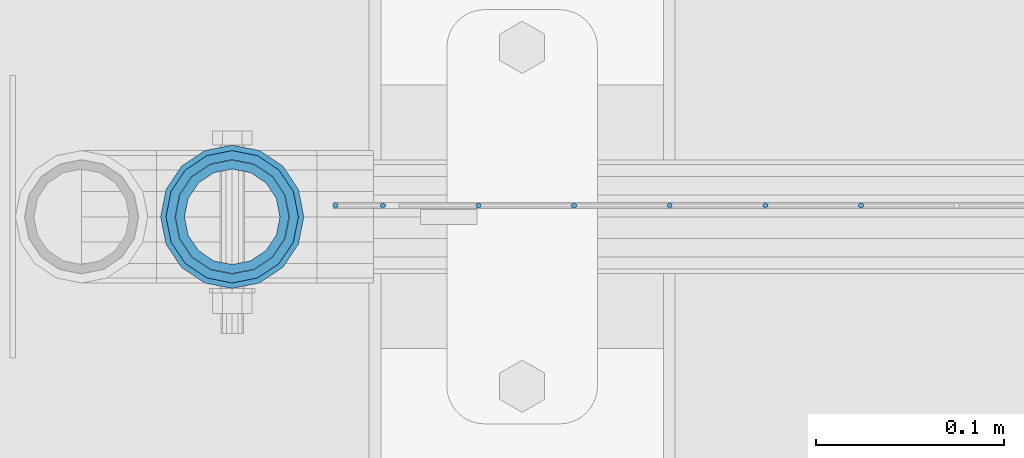
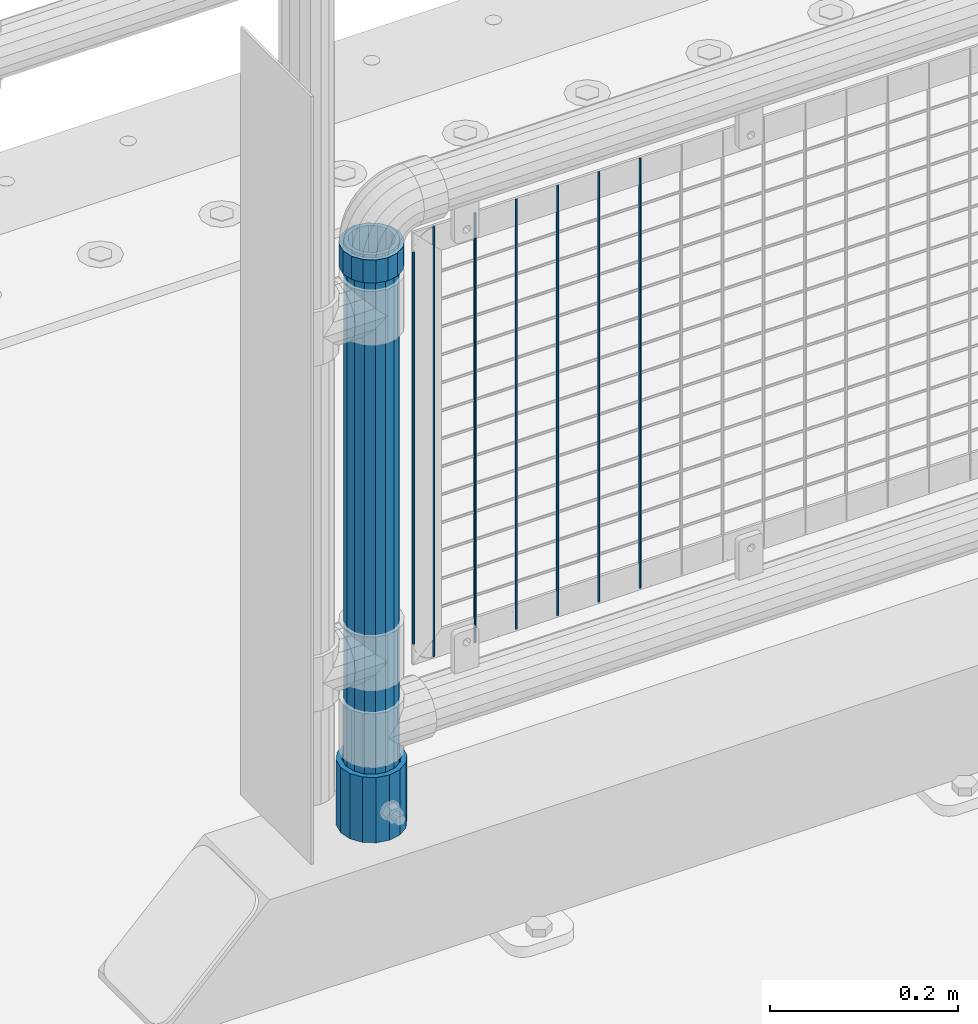
# One storey, part 61 of 242: 10 columns.
"""IFC2X3 building model written with IfcOpenShell, lengths in millimetres."""

from ifc_helpers import new_model, si_unit, frame, origin_with_axes, place, context, subcontext, project, spatial, faceted_brep, material, type_object, element, save


model = new_model("IFC2X3")

# Units and contexts
model_context = context("Model", 3, precision=1e-05, world=origin_with_axes())
body_context = subcontext(model_context, "Body", "Model", "MODEL_VIEW")
ifc_project = project(units=[si_unit("LENGTHUNIT", "METRE", prefix="MILLI"), si_unit("AREAUNIT", "SQUARE_METRE"), si_unit("VOLUMEUNIT", "CUBIC_METRE"), si_unit("MASSUNIT", "GRAM", prefix="KILO"), si_unit("TIMEUNIT", "SECOND"), si_unit("PLANEANGLEUNIT", "RADIAN"), si_unit("SOLIDANGLEUNIT", "STERADIAN"), si_unit("THERMODYNAMICTEMPERATUREUNIT", "DEGREE_CELSIUS"), si_unit("LUMINOUSINTENSITYUNIT", "LUMEN")], contexts=[model_context])

# Site, building, storey
site_placement = place(None, origin_with_axes())
site = spatial("IfcSite", under=ifc_project, at=site_placement, CompositionType="ELEMENT")
building_placement = place(site_placement, origin_with_axes())
building = spatial("IfcBuilding", under=site, at=building_placement, Name="Standard", CompositionType="ELEMENT")
storey_placement = place(building_placement, origin_with_axes())
storey = spatial("IfcBuildingStorey", under=building, at=storey_placement, Name="Undefined", CompositionType="ELEMENT", Elevation=0.0)

# Columns
ifc_material_1 = material()
column_type_1 = type_object("IfcColumnType", PredefinedType="NOTDEFINED")
column_1_placement = place(storey_placement, frame((-41829.0, -19335.5, 168.02), z_axis=(-1.0, 0.0, 0.0), x_axis=(0.0, 0.0, 1.0)))
element("IfcColumn", 1, at=column_1_placement, inside=storey, type_object=column_type_1, material=ifc_material_1, context=body_context, shape_type="Brep", body=[
    faceted_brep([(0.0, -25.3499999999985, 0.0), (0.0, -23.4203461491597, 9.70102501045403), (760.0, -23.4203461491597, 9.70102501045403), (760.0, -25.3499999999985, 0.0), (0.0, -17.9251569030785, 17.9251569030785), (760.0, -17.9251569030785, 17.9251569030785), (0.0, -9.70102501045403, 23.4203461491597), (760.0, -9.70102501045403, 23.4203461491597), (0.0, 0.0, 25.3499999999985), (760.0, 0.0, 25.3499999999985), (0.0, 9.70102501045403, 23.4203461491597), (760.0, 9.70102501045403, 23.4203461491597), (0.0, 17.9251569030785, 17.9251569030785), (760.0, 17.9251569030785, 17.9251569030785), (0.0, 23.4203461491597, 9.70102501045403), (760.0, 23.4203461491597, 9.70102501045403), (0.0, 25.3499999999985, 0.0), (760.0, 25.3499999999985, 0.0), (0.0, 23.4203461491597, -9.70102501045403), (760.0, 23.4203461491597, -9.70102501045403), (0.0, 17.9251569030785, -17.9251569030785), (760.0, 17.9251569030785, -17.9251569030785), (0.0, 9.70102501045403, -23.4203461491597), (760.0, 9.70102501045403, -23.4203461491597), (0.0, 0.0, -25.3499999999985), (760.0, 0.0, -25.3499999999985), (0.0, -9.70102501045403, -23.4203461491597), (760.0, -9.70102501045403, -23.4203461491597), (0.0, -17.9251569030785, -17.9251569030785), (760.0, -17.9251569030785, -17.9251569030785), (0.0, -23.4203461491597, -9.70102501045403), (760.0, -23.4203461491597, -9.70102501045403), (0.0, -30.1500000000015, 0.0), (0.0, -27.8549679052157, -11.5379054858058), (760.0, -27.8549679052157, -11.5379054858058), (760.0, -30.1500000000015, 0.0), (0.0, -21.3192694527752, -21.3192694527752), (760.0, -21.3192694527752, -21.3192694527752), (0.0, -11.5379054858058, -27.8549679052157), (760.0, -11.5379054858058, -27.8549679052157), (0.0, 0.0, -30.1500000000015), (760.0, 0.0, -30.1500000000015), (0.0, 11.5379054858058, -27.8549679052157), (760.0, 11.5379054858058, -27.8549679052157), (0.0, 21.3192694527752, -21.3192694527752), (760.0, 21.3192694527752, -21.3192694527752), (0.0, 27.8549679052157, -11.5379054858058), (760.0, 27.8549679052157, -11.5379054858058), (0.0, 30.1500000000015, 0.0), (760.0, 30.1500000000015, 0.0), (0.0, 27.8549679052157, 11.5379054858058), (760.0, 27.8549679052157, 11.5379054858058), (0.0, 21.3192694527752, 21.3192694527752), (760.0, 21.3192694527752, 21.3192694527752), (0.0, 11.5379054858058, 27.8549679052157), (760.0, 11.5379054858058, 27.8549679052157), (0.0, 0.0, 30.1500000000015), (760.0, 0.0, 30.1500000000015), (0.0, -11.5379054858058, 27.8549679052157), (760.0, -11.5379054858058, 27.8549679052157), (0.0, -21.3192694527752, 21.3192694527752), (760.0, -21.3192694527752, 21.3192694527752), (0.0, -27.8549679052157, 11.5379054858058), (760.0, -27.8549679052157, 11.5379054858058)], [[[0, 1, 2, 3]], [[1, 4, 5, 2]], [[4, 6, 7, 5]], [[6, 8, 9, 7]], [[8, 10, 11, 9]], [[10, 12, 13, 11]], [[12, 14, 15, 13]], [[14, 16, 17, 15]], [[16, 18, 19, 17]], [[18, 20, 21, 19]], [[20, 22, 23, 21]], [[22, 24, 25, 23]], [[24, 26, 27, 25]], [[26, 28, 29, 27]], [[28, 30, 31, 29]], [[30, 0, 3, 31]], [[32, 33, 34, 35]], [[33, 36, 37, 34]], [[36, 38, 39, 37]], [[38, 40, 41, 39]], [[40, 42, 43, 41]], [[42, 44, 45, 43]], [[44, 46, 47, 45]], [[46, 48, 49, 47]], [[48, 50, 51, 49]], [[50, 52, 53, 51]], [[52, 54, 55, 53]], [[54, 56, 57, 55]], [[56, 58, 59, 57]], [[58, 60, 61, 59]], [[60, 62, 63, 61]], [[62, 32, 35, 63]], [[37, 39, 41, 43, 45, 47, 49, 51, 53, 55, 57, 59, 61, 63, 35, 34], [5, 7, 9, 11, 13, 15, 17, 19, 21, 23, 25, 27, 29, 31, 3, 2]], [[62, 60, 58, 56, 54, 52, 50, 48, 46, 44, 42, 40, 38, 36, 33, 32], [30, 28, 26, 24, 22, 20, 18, 16, 14, 12, 10, 8, 6, 4, 1, 0]]]),
])
ifc_material_2 = material(Name="Misc_Undefined")
column_type_2 = type_object("IfcColumnType", PredefinedType="NOTDEFINED")
column_2_placement = place(storey_placement, frame((-41829.0, -19335.5, 894.849999999999), z_axis=(-1.0, 0.0, 0.0), x_axis=(0.0, 0.0, 1.0)))
element("IfcColumn", 2, at=column_2_placement, inside=storey, type_object=column_type_2, material=ifc_material_2, context=body_context, shape_type="Brep", body=[
    faceted_brep([(0.0, -30.3499999999985, 0.0), (0.0, -28.0397438117179, 11.6144421722784), (30.0, -28.0397438117179, 11.6144421722805), (30.0, -30.3499999999985, 0.0), (0.0, -21.46069080901, 21.4606908090136), (30.0, -21.46069080901, 21.4606908090117), (0.0, -11.614442172282, 28.0397438117143), (30.0, -11.614442172282, 28.0397438117176), (0.0, 0.0, 30.3499999999985), (30.0, 0.0, 30.35), (0.0, 11.614442172282, 28.0397438117143), (30.0, 11.614442172282, 28.0397438117176), (0.0, 21.46069080901, 21.4606908090136), (30.0, 21.46069080901, 21.4606908090117), (0.0, 28.0397438117179, 11.6144421722784), (30.0, 28.0397438117179, 11.6144421722805), (0.0, 30.3499999999985, 0.0), (30.0, 30.3499999999985, 0.0), (0.0, 28.0397438117179, -11.6144421722784), (30.0, 28.0397438117179, -11.6144421722805), (0.0, 21.46069080901, -21.4606908090136), (30.0, 21.46069080901, -21.4606908090117), (0.0, 11.614442172282, -28.0397438117143), (30.0, 11.614442172282, -28.0397438117176), (0.0, 0.0, -30.3499999999985), (30.0, 0.0, -30.35), (0.0, -11.614442172282, -28.0397438117143), (30.0, -11.614442172282, -28.0397438117176), (0.0, -21.46069080901, -21.4606908090136), (30.0, -21.46069080901, -21.4606908090117), (0.0, -28.0397438117179, -11.6144421722784), (30.0, -28.0397438117179, -11.6144421722805), (0.0, -35.1500000000015, 0.0), (0.0, -32.4743655677703, -13.4513226476338), (30.0, -32.4743655677703, -13.4513226476329), (30.0, -35.1500000000015, 0.0), (0.0, -24.8548033587067, -24.8548033587067), (30.0, -24.8548033587067, -24.8548033587072), (0.0, -13.4513226476338, -32.4743655677739), (30.0, -13.4513226476338, -32.4743655677718), (0.0, 0.0, -35.1500000000015), (30.0, 0.0, -35.15), (0.0, 13.4513226476338, -32.4743655677739), (30.0, 13.4513226476338, -32.4743655677718), (0.0, 24.8548033587067, -24.8548033587067), (30.0, 24.8548033587067, -24.8548033587072), (0.0, 32.4743655677703, -13.4513226476338), (30.0, 32.4743655677703, -13.4513226476329), (0.0, 35.1500000000015, 0.0), (30.0, 35.1500000000015, 0.0), (0.0, 32.4743655677703, 13.4513226476338), (30.0, 32.4743655677703, 13.4513226476329), (0.0, 24.8548033587067, 24.8548033587067), (30.0, 24.8548033587067, 24.8548033587072), (0.0, 13.4513226476338, 32.4743655677739), (30.0, 13.4513226476338, 32.4743655677718), (0.0, 0.0, 35.1500000000015), (30.0, 0.0, 35.15), (0.0, -13.4513226476338, 32.4743655677739), (30.0, -13.4513226476338, 32.4743655677718), (0.0, -24.8548033587067, 24.8548033587067), (30.0, -24.8548033587067, 24.8548033587072), (0.0, -32.4743655677703, 13.4513226476338), (30.0, -32.4743655677703, 13.4513226476329)], [[[0, 1, 2, 3]], [[1, 4, 5, 2]], [[4, 6, 7, 5]], [[6, 8, 9, 7]], [[8, 10, 11, 9]], [[10, 12, 13, 11]], [[12, 14, 15, 13]], [[14, 16, 17, 15]], [[16, 18, 19, 17]], [[18, 20, 21, 19]], [[20, 22, 23, 21]], [[22, 24, 25, 23]], [[24, 26, 27, 25]], [[26, 28, 29, 27]], [[28, 30, 31, 29]], [[30, 0, 3, 31]], [[32, 33, 34, 35]], [[33, 36, 37, 34]], [[36, 38, 39, 37]], [[38, 40, 41, 39]], [[40, 42, 43, 41]], [[42, 44, 45, 43]], [[44, 46, 47, 45]], [[46, 48, 49, 47]], [[48, 50, 51, 49]], [[50, 52, 53, 51]], [[52, 54, 55, 53]], [[54, 56, 57, 55]], [[56, 58, 59, 57]], [[58, 60, 61, 59]], [[60, 62, 63, 61]], [[62, 32, 35, 63]], [[37, 39, 41, 43, 45, 47, 49, 51, 53, 55, 57, 59, 61, 63, 35, 34], [5, 7, 9, 11, 13, 15, 17, 19, 21, 23, 25, 27, 29, 31, 3, 2]], [[62, 60, 58, 56, 54, 52, 50, 48, 46, 44, 42, 40, 38, 36, 33, 32], [30, 28, 26, 24, 22, 20, 18, 16, 14, 12, 10, 8, 6, 4, 1, 0]]]),
])
column_type_3 = type_object("IfcColumnType", Name="D3", PredefinedType="NOTDEFINED")
for number, where, z_axis, x_axis in (
    (3, (-41495.035, -19329.5, 353.02), (-1.0, 0.0, 0.0), (0.0, 0.0, 1.0)),
    (4, (-41545.828, -19329.5, 353.02), (-1.0, 0.0, 0.0), (0.0, 0.0, 1.0)),
    (5, (-41596.621, -19329.5, 353.02), (-1.0, 0.0, 0.0), (0.0, 0.0, 1.0)),
    (6, (-41647.414, -19329.5, 353.02), (-1.0, 0.0, 0.0), (0.0, 0.0, 1.0)),
    (7, (-41698.207, -19329.5, 353.02), (-1.0, 0.0, 0.0), (0.0, 0.0, 1.0)),
):
    element("IfcColumn", number, at=place(storey_placement, frame(where, z_axis=z_axis, x_axis=x_axis)), inside=storey, type_object=column_type_3, material=ifc_material_2, ObjectType="D3", context=body_context, shape_type="Brep", body=[
        faceted_brep([(0.0, -1.50000000000364, 0.0), (-3.63797880709171e-12, -0.750000000003638, -1.29903810567669), (560.0, -0.75, -1.29903810567703), (560.0, -1.5, 0.0), (0.0, 0.749999999996362, -1.29903810567669), (560.0, 0.75, -1.29903810567703), (-3.63797880709171e-12, 1.49999999999636, 0.0), (560.0, 1.5, 0.0), (0.0, 0.749999999996362, 1.29903810567669), (560.0, 0.75, 1.29903810567703), (-3.63797880709171e-12, -0.750000000003638, 1.29903810567669), (560.0, -0.75, 1.29903810567703)], [[[0, 1, 2, 3]], [[1, 4, 5, 2]], [[4, 6, 7, 5]], [[6, 8, 9, 7]], [[8, 10, 11, 9]], [[10, 0, 3, 11]], [[5, 7, 9, 11, 3, 2]], [[10, 8, 6, 4, 1, 0]]]),
    ])
column_3_placement = place(storey_placement, frame((-41774.0, -19329.5, 378.02), z_axis=(-1.0, 0.0, 0.0), x_axis=(0.0, 0.0, 1.0)))
element("IfcColumn", 8, at=column_3_placement, inside=storey, type_object=column_type_3, material=ifc_material_2, ObjectType="D3", context=body_context, shape_type="Brep", body=[
    faceted_brep([(0.0, -1.50000000000364, 0.0), (-3.63797880709171e-12, -0.750000000003638, -1.29903810567669), (510.0, -0.75, -1.29903810567703), (510.0, -1.5, 0.0), (0.0, 0.749999999996362, -1.29903810567669), (510.0, 0.75, -1.29903810567703), (-3.63797880709171e-12, 1.49999999999636, 0.0), (510.0, 1.5, 0.0), (0.0, 0.749999999996362, 1.29903810567669), (510.0, 0.75, 1.29903810567703), (-3.63797880709171e-12, -0.750000000003638, 1.29903810567669), (510.0, -0.75, 1.29903810567703)], [[[0, 1, 2, 3]], [[1, 4, 5, 2]], [[4, 6, 7, 5]], [[6, 8, 9, 7]], [[8, 10, 11, 9]], [[10, 0, 3, 11]], [[5, 7, 9, 11, 3, 2]], [[10, 8, 6, 4, 1, 0]]]),
])
column_4_placement = place(storey_placement, frame((-41749.0, -19329.5, 353.02), z_axis=(-1.0, 0.0, 0.0), x_axis=(0.0, 0.0, 1.0)))
element("IfcColumn", 9, at=column_4_placement, inside=storey, type_object=column_type_3, material=ifc_material_2, ObjectType="D3", context=body_context, shape_type="Brep", body=[
    faceted_brep([(0.0, -1.50000000000364, 0.0), (-3.63797880709171e-12, -0.750000000003638, -1.29903810567669), (560.0, -0.75, -1.29903810567703), (560.0, -1.5, 0.0), (0.0, 0.749999999996362, -1.29903810567669), (560.0, 0.75, -1.29903810567703), (-3.63797880709171e-12, 1.49999999999636, 0.0), (560.0, 1.5, 0.0), (0.0, 0.749999999996362, 1.29903810567669), (560.0, 0.75, 1.29903810567703), (-3.63797880709171e-12, -0.750000000003638, 1.29903810567669), (560.0, -0.75, 1.29903810567703)], [[[0, 1, 2, 3]], [[1, 4, 5, 2]], [[4, 6, 7, 5]], [[6, 8, 9, 7]], [[8, 10, 11, 9]], [[10, 0, 3, 11]], [[5, 7, 9, 11, 3, 2]], [[10, 8, 6, 4, 1, 0]]]),
])
column_type_4 = type_object("IfcColumnType", PredefinedType="NOTDEFINED")
column_5_placement = place(storey_placement, frame((-41829.0, -19335.5, 168.02), z_axis=(0.0, 1.0, 0.0), x_axis=(0.0, 0.0, 1.0)))
element("IfcColumn", 10, at=column_5_placement, inside=storey, type_object=column_type_4, material=ifc_material_1, context=body_context, shape_type="Brep", body=[
    faceted_brep([(0.0, -31.75, 0.0), (0.0, -29.3331751572332, 12.1501989775934), (85.0, -29.3331751572332, 12.1501989775934), (85.0, -31.75, 0.0), (0.0, -22.4506403026717, 22.4506403026717), (85.0, -22.4506403026717, 22.4506403026717), (0.0, -12.1501989775934, 29.3331751572332), (85.0, -12.1501989775934, 29.3331751572332), (0.0, 0.0, 31.75), (85.0, 0.0, 31.75), (0.0, 12.1501989775934, 29.3331751572332), (85.0, 12.1501989775934, 29.3331751572332), (0.0, 22.4506403026717, 22.4506403026717), (85.0, 22.4506403026717, 22.4506403026717), (0.0, 29.3331751572332, 12.1501989775934), (85.0, 29.3331751572332, 12.1501989775934), (0.0, 31.75, 0.0), (85.0, 31.75, 0.0), (0.0, 29.3331751572332, -12.1501989775934), (85.0, 29.3331751572332, -12.1501989775934), (0.0, 22.4506403026717, -22.4506403026717), (85.0, 22.4506403026717, -22.4506403026717), (0.0, 12.1501989775934, -29.3331751572332), (85.0, 12.1501989775934, -29.3331751572332), (0.0, 0.0, -31.75), (85.0, 0.0, -31.75), (0.0, -12.1501989775934, -29.3331751572332), (85.0, -12.1501989775934, -29.3331751572332), (0.0, -22.4506403026717, -22.4506403026717), (85.0, -22.4506403026717, -22.4506403026717), (0.0, -29.3331751572332, -12.1501989775934), (85.0, -29.3331751572332, -12.1501989775934), (0.0, -38.0499999999993, 0.0), (0.0, -35.1536162120537, -14.5611046014928), (85.0, -35.1536162120537, -14.5611046014928), (85.0, -38.0499999999993, 0.0), (0.0, -26.9054130241493, -26.9054130241493), (85.0, -26.9054130241493, -26.9054130241493), (0.0, -14.5611046014928, -35.1536162120537), (85.0, -14.5611046014928, -35.1536162120537), (0.0, 0.0, -38.0499999999993), (85.0, 0.0, -38.0499999999993), (0.0, 14.5611046014928, -35.1536162120537), (85.0, 14.5611046014928, -35.1536162120537), (0.0, 26.9054130241493, -26.9054130241493), (85.0, 26.9054130241493, -26.9054130241493), (0.0, 35.1536162120537, -14.5611046014928), (85.0, 35.1536162120537, -14.5611046014928), (0.0, 38.0499999999993, 0.0), (85.0, 38.0499999999993, 0.0), (0.0, 35.1536162120537, 14.5611046014928), (85.0, 35.1536162120537, 14.5611046014928), (0.0, 26.9054130241493, 26.9054130241493), (85.0, 26.9054130241493, 26.9054130241493), (0.0, 14.5611046014928, 35.1536162120537), (85.0, 14.5611046014928, 35.1536162120537), (0.0, 0.0, 38.0499999999993), (85.0, 0.0, 38.0499999999993), (0.0, -14.5611046014928, 35.1536162120537), (85.0, -14.5611046014928, 35.1536162120537), (0.0, -26.9054130241493, 26.9054130241493), (85.0, -26.9054130241493, 26.9054130241493), (0.0, -35.1536162120537, 14.5611046014928), (85.0, -35.1536162120537, 14.5611046014928)], [[[0, 1, 2, 3]], [[1, 4, 5, 2]], [[4, 6, 7, 5]], [[6, 8, 9, 7]], [[8, 10, 11, 9]], [[10, 12, 13, 11]], [[12, 14, 15, 13]], [[14, 16, 17, 15]], [[16, 18, 19, 17]], [[18, 20, 21, 19]], [[20, 22, 23, 21]], [[22, 24, 25, 23]], [[24, 26, 27, 25]], [[26, 28, 29, 27]], [[28, 30, 31, 29]], [[30, 0, 3, 31]], [[32, 33, 34, 35]], [[33, 36, 37, 34]], [[36, 38, 39, 37]], [[38, 40, 41, 39]], [[40, 42, 43, 41]], [[42, 44, 45, 43]], [[44, 46, 47, 45]], [[46, 48, 49, 47]], [[48, 50, 51, 49]], [[50, 52, 53, 51]], [[52, 54, 55, 53]], [[54, 56, 57, 55]], [[56, 58, 59, 57]], [[58, 60, 61, 59]], [[60, 62, 63, 61]], [[62, 32, 35, 63]], [[37, 39, 41, 43, 45, 47, 49, 51, 53, 55, 57, 59, 61, 63, 35, 34], [5, 7, 9, 11, 13, 15, 17, 19, 21, 23, 25, 27, 29, 31, 3, 2]], [[62, 60, 58, 56, 54, 52, 50, 48, 46, 44, 42, 40, 38, 36, 33, 32], [30, 28, 26, 24, 22, 20, 18, 16, 14, 12, 10, 8, 6, 4, 1, 0]]]),
])

save(model, "model.ifc")
